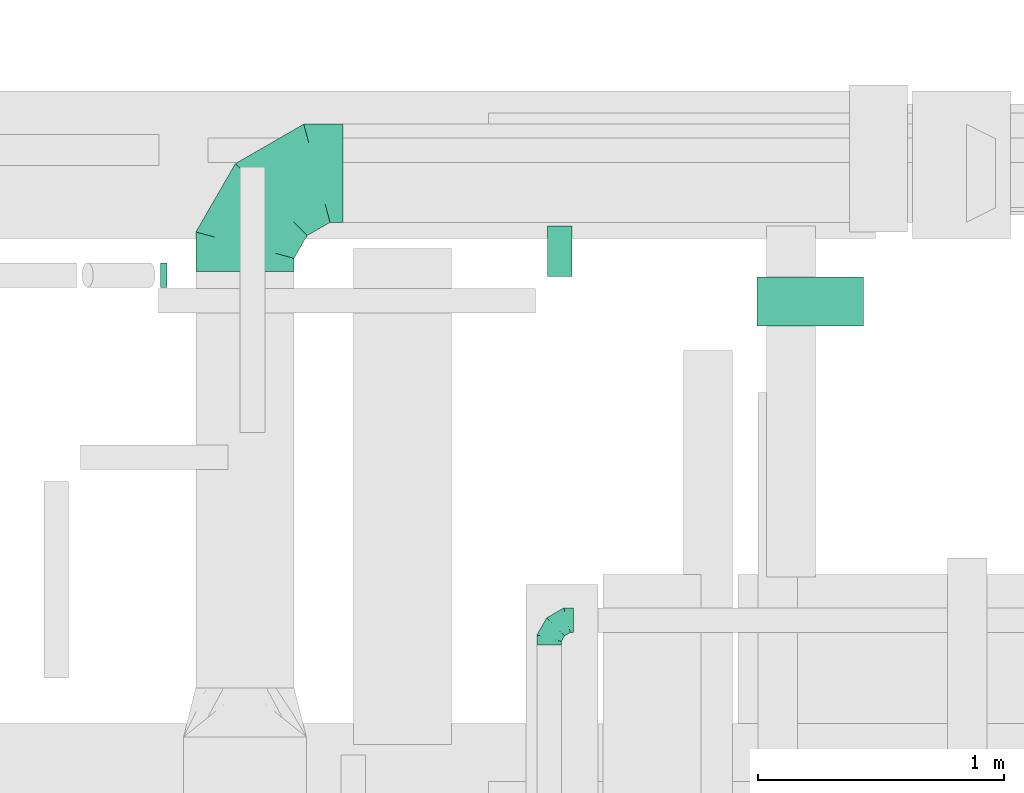
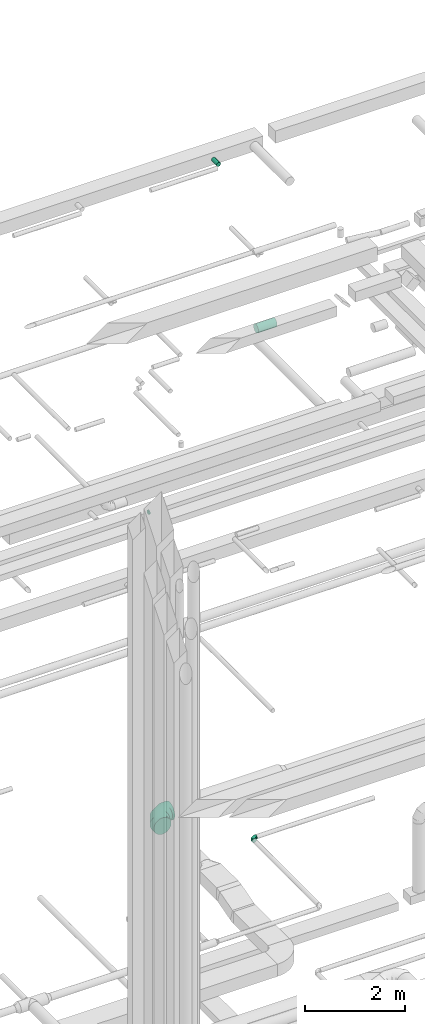
# One storey, part 158 of 337: 3 flow segments, 2 flow fittings.
"""IFC2X3 building model written with IfcOpenShell, lengths in millimetres."""

from ifc_helpers import new_model, entity, si_unit, converted_unit, derived_unit, direction, frame, origin, origin_2d_with_axis, place, context, subcontext, project, spatial, circle, extrude, faceted_brep, source, transform, mapped, material, type_object, type_shapes, element, save


model = new_model("IFC2X3")

# Units and contexts
model_context = context("Model", 3, precision=0.01, world=origin(), true_north=direction((6.12303176911189e-17, 1.0)))
body_context = subcontext(model_context, "Body", "Model", "MODEL_VIEW")
ifc_project = project(units=[si_unit("LENGTHUNIT", "METRE", prefix="MILLI"), si_unit("AREAUNIT", "SQUARE_METRE"), si_unit("VOLUMEUNIT", "CUBIC_METRE"), converted_unit("PLANEANGLEUNIT", "DEGREE", entity("IfcRatioMeasure", 0.0174532925199433), si_unit("PLANEANGLEUNIT", "RADIAN"), dimensions=[0, 0, 0, 0, 0, 0, 0]), si_unit("MASSUNIT", "GRAM", prefix="KILO"), derived_unit("MASSDENSITYUNIT", [(si_unit("MASSUNIT", "GRAM", prefix="KILO"), 1), (si_unit("LENGTHUNIT", "METRE"), -3)]), derived_unit("MOMENTOFINERTIAUNIT", [(si_unit("LENGTHUNIT", "METRE"), 4)]), si_unit("TIMEUNIT", "SECOND"), si_unit("FREQUENCYUNIT", "HERTZ"), si_unit("THERMODYNAMICTEMPERATUREUNIT", "DEGREE_CELSIUS"), derived_unit("THERMALTRANSMITTANCEUNIT", [(si_unit("MASSUNIT", "GRAM", prefix="KILO"), 1), (si_unit("THERMODYNAMICTEMPERATUREUNIT", "KELVIN"), -1), (si_unit("TIMEUNIT", "SECOND"), -3)]), derived_unit("VOLUMETRICFLOWRATEUNIT", [(si_unit("LENGTHUNIT", "METRE"), 3), (si_unit("TIMEUNIT", "SECOND"), -1)]), derived_unit("MASSFLOWRATEUNIT", [(si_unit("MASSUNIT", "GRAM", prefix="KILO"), 1), (si_unit("TIMEUNIT", "SECOND"), -1)]), derived_unit("ROTATIONALFREQUENCYUNIT", [(si_unit("TIMEUNIT", "SECOND"), -1)]), si_unit("ELECTRICCURRENTUNIT", "AMPERE"), si_unit("ELECTRICVOLTAGEUNIT", "VOLT"), si_unit("POWERUNIT", "WATT"), si_unit("FORCEUNIT", "NEWTON", prefix="KILO"), si_unit("ILLUMINANCEUNIT", "LUX"), si_unit("LUMINOUSFLUXUNIT", "LUMEN"), si_unit("LUMINOUSINTENSITYUNIT", "CANDELA"), derived_unit("USERDEFINED", [(si_unit("MASSUNIT", "GRAM", prefix="KILO"), -1), (si_unit("LENGTHUNIT", "METRE"), -2), (si_unit("TIMEUNIT", "SECOND"), 3), (si_unit("LUMINOUSFLUXUNIT", "LUMEN"), 1)]), derived_unit("LINEARVELOCITYUNIT", [(si_unit("LENGTHUNIT", "METRE"), 1), (si_unit("TIMEUNIT", "SECOND"), -1)]), si_unit("PRESSUREUNIT", "PASCAL"), derived_unit("USERDEFINED", [(si_unit("LENGTHUNIT", "METRE"), -2), (si_unit("MASSUNIT", "GRAM", prefix="KILO"), 1), (si_unit("TIMEUNIT", "SECOND"), -2)]), derived_unit("LINEARFORCEUNIT", [(si_unit("MASSUNIT", "GRAM", prefix="KILO"), 1), (si_unit("LENGTHUNIT", "METRE"), 1), (si_unit("TIMEUNIT", "SECOND"), -2), (si_unit("LENGTHUNIT", "METRE"), -1)]), derived_unit("PLANARFORCEUNIT", [(si_unit("MASSUNIT", "GRAM", prefix="KILO"), 1), (si_unit("LENGTHUNIT", "METRE"), 1), (si_unit("TIMEUNIT", "SECOND"), -2), (si_unit("LENGTHUNIT", "METRE"), -2)])], contexts=[model_context])

# Site, building, storey
site_placement = place(None, origin())
site = spatial("IfcSite", under=ifc_project, at=site_placement, CompositionType="ELEMENT")
building_placement = place(site_placement, origin())
building = spatial("IfcBuilding", under=site, at=building_placement, CompositionType="ELEMENT")
storey_placement = place(building_placement, origin())
storey = spatial("IfcBuildingStorey", under=building, at=storey_placement, CompositionType="ELEMENT", Elevation=0.0)

# Flow segments
duct_segment_type = type_object("IfcDuctSegmentType", PredefinedType="NOTDEFINED")
flow_segment_1_placement = place(storey_placement, frame((34979.29, 19353.19, 11198.4)))
element("IfcFlowSegment", 1, at=flow_segment_1_placement, inside=storey, type_object=duct_segment_type, context=body_context, shape_type="SweptSolid", body=[
    extrude(circle(Radius=50.0, at=origin_2d_with_axis()), frame((0.0, 51.6, 51.6), z_axis=(1.0, 0.0, 0.0), x_axis=(0.0, -1.0, 0.0)), (0.0, 0.0, 1.0), 26.1790715644626),
])
flow_segment_2_placement = place(storey_placement, frame((37407.95, 19195.94, 14848.4)))
element("IfcFlowSegment", 2, at=flow_segment_2_placement, inside=storey, type_object=duct_segment_type, context=body_context, shape_type="SweptSolid", body=[
    extrude(circle(Radius=100.0, at=origin_2d_with_axis()), frame((0.0, 101.6, 101.6), z_axis=(1.0, 0.0, 0.0), x_axis=(0.0, -1.0, 0.0)), (0.0, 0.0, 1.0), 433.176827525416),
])
flow_segment_3_placement = place(storey_placement, frame((36553.36, 19399.7, 19118.4)))
element("IfcFlowSegment", 3, at=flow_segment_3_placement, inside=storey, type_object=duct_segment_type, context=body_context, shape_type="SweptSolid", body=[
    extrude(circle(Radius=50.0, at=origin_2d_with_axis()), frame((51.6, 0.0, 51.6), z_axis=(0.0, 1.0, 0.0), x_axis=(-1.0, 0.0, 0.0)), (0.0, 0.0, 1.0), 205.624999999981),
])

# Flow fittings
ifc_material = material()
duct_fitting_type_1 = type_object("IfcDuctFittingType", PredefinedType="NOTDEFINED", material=ifc_material)
shared_shape_1 = source(origin(), body_context, "Body", "Brep", [
    faceted_brep([(-100.0, 0.0, -50.0), (-100.0, -12.94, -48.3), (-100.0, -25.0, -43.3), (-100.0, -35.36, -35.36), (-100.0, -43.3, -25.0), (-100.0, -48.3, -12.94), (-100.0, -50.0, 0.0), (-100.0, -48.3, 12.94), (-100.0, -43.3, 25.0), (-100.0, -35.36, 35.36), (-100.0, -25.0, 43.3), (-100.0, -12.94, 48.3), (-100.0, 0.0, 50.0), (-100.0, 12.94, 48.3), (-100.0, 25.0, 43.3), (-100.0, 35.36, 35.36), (-100.0, 43.3, 25.0), (-100.0, 48.3, 12.94), (-100.0, 50.0, 0.0), (-100.0, 48.3, -12.94), (-100.0, 43.3, -25.0), (-100.0, 35.36, -35.36), (-100.0, 25.0, -43.3), (-100.0, 12.94, -48.3), (-76.67, 12.94, 48.3), (-79.9, 25.0, 43.3), (-73.21, 0.0, 50.0), (-82.68, 35.36, 35.36), (-86.15, 48.3, 12.94), (-86.6, 50.0, 0.0), (-84.81, 43.3, 25.0), (-84.81, 43.3, -25.0), (-82.68, 35.36, -35.36), (-86.15, 48.3, -12.94), (-76.67, 12.94, -48.3), (-73.21, 0.0, -50.0), (-79.9, 25.0, -43.3), (-69.74, -12.94, -48.3), (-66.51, -25.0, -43.3), (-63.73, -35.36, -35.36), (-61.6, -43.3, -25.0), (-60.26, -48.3, -12.94), (-59.81, -50.0, 0.0), (-60.26, -48.3, 12.94), (-61.6, -43.3, 25.0), (-63.73, -35.36, 35.36), (-66.51, -25.0, 43.3), (-69.74, -12.94, 48.3), (-36.27, 36.27, 48.3), (-45.1, 45.1, 43.3), (-26.79, 26.79, 50.0), (-52.68, 52.68, 35.36), (-58.49, 58.49, 25.0), (-62.15, 62.15, 12.94), (-63.4, 63.4, 0.0), (-62.15, 62.15, -12.94), (-58.49, 58.49, -25.0), (-52.68, 52.68, -35.36), (-36.27, 36.27, -48.3), (-26.79, 26.79, -50.0), (-45.1, 45.1, -43.3), (-17.32, 17.32, -48.3), (-8.49, 8.49, -43.3), (-0.91, 0.91, -35.36), (4.9, -4.9, -25.0), (8.56, -8.56, -12.94), (9.81, -9.81, 0.0), (8.56, -8.56, 12.94), (4.9, -4.9, 25.0), (-0.91, 0.91, 35.36), (-8.49, 8.49, 43.3), (-17.32, 17.32, 48.3), (-12.94, 76.67, 48.3), (-25.0, 79.9, 43.3), (0.0, 73.21, 50.0), (-35.36, 82.68, 35.36), (-43.3, 84.81, 25.0), (-48.3, 86.15, 12.94), (-50.0, 86.6, 0.0), (-48.3, 86.15, -12.94), (-43.3, 84.81, -25.0), (-35.36, 82.68, -35.36), (-12.94, 76.67, -48.3), (0.0, 73.21, -50.0), (-25.0, 79.9, -43.3), (12.94, 69.74, -48.3), (25.0, 66.51, -43.3), (35.36, 63.73, -35.36), (43.3, 61.6, -25.0), (48.3, 60.26, -12.94), (50.0, 59.81, 0.0), (48.3, 60.26, 12.94), (43.3, 61.6, 25.0), (35.36, 63.73, 35.36), (25.0, 66.51, 43.3), (12.94, 69.74, 48.3), (-12.94, 100.0, -48.3), (-25.0, 100.0, -43.3), (-35.36, 100.0, -35.36), (-43.3, 100.0, -25.0), (-48.3, 100.0, -12.94), (-50.0, 100.0, 0.0), (-48.3, 100.0, 12.94), (-43.3, 100.0, 25.0), (-35.36, 100.0, 35.36), (-25.0, 100.0, 43.3), (-12.94, 100.0, 48.3), (0.0, 100.0, 50.0), (12.94, 100.0, 48.3), (25.0, 100.0, 43.3), (35.36, 100.0, 35.36), (43.3, 100.0, 25.0), (48.3, 100.0, 12.94), (50.0, 100.0, 0.0), (48.3, 100.0, -12.94), (43.3, 100.0, -25.0), (35.36, 100.0, -35.36), (25.0, 100.0, -43.3), (12.94, 100.0, -48.3), (0.0, 100.0, -50.0)], [[[0, 1, 2, 3, 4, 5, 6, 7, 8, 9, 10, 11, 12, 13, 14, 15, 16, 17, 18, 19, 20, 21, 22, 23]], [[24, 25, 14, 13]], [[26, 24, 13, 12]], [[14, 25, 27, 15]], [[28, 29, 18, 17]], [[30, 28, 17, 16]], [[15, 27, 30, 16]], [[20, 31, 32, 21]], [[33, 31, 20, 19]], [[18, 29, 33, 19]], [[34, 35, 0, 23]], [[36, 34, 23, 22]], [[32, 36, 22, 21]], [[2, 1, 37, 38]], [[3, 2, 38, 39]], [[0, 35, 37, 1]], [[5, 4, 40, 41]], [[6, 5, 41, 42]], [[3, 39, 40, 4]], [[6, 42, 43, 7]], [[7, 43, 44, 8]], [[8, 44, 45, 9]], [[10, 46, 47, 11]], [[11, 47, 26, 12]], [[10, 9, 45, 46]], [[48, 49, 25, 24]], [[50, 48, 24, 26]], [[27, 25, 49, 51]], [[52, 53, 28, 30]], [[51, 52, 30, 27]], [[29, 28, 53, 54]], [[55, 56, 31, 33]], [[54, 55, 33, 29]], [[57, 32, 31, 56]], [[58, 59, 35, 34]], [[60, 58, 34, 36]], [[57, 60, 36, 32]], [[37, 35, 59, 61]], [[38, 37, 61, 62]], [[39, 38, 62, 63]], [[41, 40, 64, 65]], [[42, 41, 65, 66]], [[63, 64, 40, 39]], [[43, 42, 66, 67]], [[44, 43, 67, 68]], [[68, 69, 45, 44]], [[46, 45, 69, 70]], [[47, 46, 70, 71]], [[26, 47, 71, 50]], [[72, 73, 49, 48]], [[74, 72, 48, 50]], [[51, 49, 73, 75]], [[76, 77, 53, 52]], [[75, 76, 52, 51]], [[54, 53, 77, 78]], [[79, 80, 56, 55]], [[78, 79, 55, 54]], [[81, 57, 56, 80]], [[82, 83, 59, 58]], [[84, 82, 58, 60]], [[81, 84, 60, 57]], [[61, 59, 83, 85]], [[62, 61, 85, 86]], [[63, 62, 86, 87]], [[65, 64, 88, 89]], [[66, 65, 89, 90]], [[87, 88, 64, 63]], [[67, 66, 90, 91]], [[68, 67, 91, 92]], [[92, 93, 69, 68]], [[70, 69, 93, 94]], [[71, 70, 94, 95]], [[50, 71, 95, 74]], [[96, 97, 98, 99, 100, 101, 102, 103, 104, 105, 106, 107, 108, 109, 110, 111, 112, 113, 114, 115, 116, 117, 118, 119]], [[72, 74, 107, 106]], [[73, 72, 106, 105]], [[75, 73, 105, 104]], [[77, 76, 103, 102]], [[78, 77, 102, 101]], [[75, 104, 103, 76]], [[78, 101, 100, 79]], [[79, 100, 99, 80]], [[80, 99, 98, 81]], [[96, 119, 83, 82]], [[97, 96, 82, 84]], [[84, 81, 98, 97]], [[83, 119, 118, 85]], [[85, 118, 117, 86]], [[86, 117, 116, 87]], [[88, 115, 114, 89]], [[89, 114, 113, 90]], [[87, 116, 115, 88]], [[91, 90, 113, 112]], [[92, 91, 112, 111]], [[93, 92, 111, 110]], [[95, 94, 109, 108]], [[74, 95, 108, 107]], [[110, 109, 94, 93]]]),
])
type_shapes(duct_fitting_type_1, [shared_shape_1])
flow_fitting_1_placement = place(storey_placement, frame((36561.25, 17999.47, 3600.0), z_axis=(0.0, 0.0, 1.0), x_axis=(-1.0, 0.0, 0.0)))
element("IfcFlowFitting", 4, at=flow_fitting_1_placement, inside=storey, type_object=duct_fitting_type_1, material=ifc_material, context=body_context, shape_type="MappedRepresentation", body=[
    mapped(shared_shape_1, transform((0.0, 0.0, 0.0), scale=1.0)),
])
duct_fitting_type_2 = type_object("IfcDuctFittingType", PredefinedType="NOTDEFINED", material=ifc_material)
shared_shape_2 = source(origin(), body_context, "Body", "Brep", [
    faceted_brep([(-400.0, 0.0, -200.0), (-400.0, -44.5, -194.99), (-400.0, -86.78, -180.19), (-400.0, -124.7, -156.37), (-400.0, -156.37, -124.7), (-400.0, -180.19, -86.78), (-400.0, -194.99, -44.5), (-400.0, -200.0, 0.0), (-400.0, -194.99, 44.5), (-400.0, -180.19, 86.78), (-400.0, -156.37, 124.7), (-400.0, -124.7, 156.37), (-400.0, -86.78, 180.19), (-400.0, -44.5, 194.99), (-400.0, 0.0, 200.0), (-400.0, 44.5, 194.99), (-400.0, 86.78, 180.19), (-400.0, 124.7, 156.37), (-400.0, 156.37, 124.7), (-400.0, 180.19, 86.78), (-400.0, 194.99, 44.5), (-400.0, 200.0, 0.0), (-400.0, 194.99, -44.5), (-400.0, 180.19, -86.78), (-400.0, 156.37, -124.7), (-400.0, 124.7, -156.37), (-400.0, 86.78, -180.19), (-400.0, 44.5, -194.99), (-292.82, 0.0, 200.0), (-304.75, 44.5, 194.99), (-316.07, 86.78, 180.19), (-326.23, 124.7, 156.37), (-334.72, 156.37, 124.7), (-341.1, 180.19, 86.78), (-345.07, 194.99, 44.5), (-346.41, 200.0, 0.0), (-345.07, 194.99, -44.5), (-341.1, 180.19, -86.78), (-334.72, 156.37, -124.7), (-326.23, 124.7, -156.37), (-316.07, 86.78, -180.19), (-304.75, 44.5, -194.99), (-292.82, 0.0, -200.0), (-280.9, -44.5, -194.99), (-269.57, -86.78, -180.19), (-259.41, -124.7, -156.37), (-250.92, -156.37, -124.7), (-244.54, -180.19, -86.78), (-240.57, -194.99, -44.5), (-239.23, -200.0, 0.0), (-240.57, -194.99, 44.5), (-244.54, -180.19, 86.78), (-250.92, -156.37, 124.7), (-259.41, -124.7, 156.37), (-269.57, -86.78, 180.19), (-280.9, -44.5, 194.99), (-107.18, 107.18, 200.0), (-139.76, 139.76, 194.99), (-170.7, 170.7, 180.19), (-198.46, 198.46, 156.37), (-221.65, 221.65, 124.7), (-239.09, 239.09, 86.78), (-249.92, 249.92, 44.5), (-253.59, 253.59, 0.0), (-249.92, 249.92, -44.5), (-239.09, 239.09, -86.78), (-221.65, 221.65, -124.7), (-198.46, 198.46, -156.37), (-170.7, 170.7, -180.19), (-139.76, 139.76, -194.99), (-107.18, 107.18, -200.0), (-74.6, 74.6, -194.99), (-43.65, 43.65, -180.19), (-15.89, 15.89, -156.37), (7.29, -7.29, -124.7), (24.73, -24.73, -86.78), (35.56, -35.56, -44.5), (39.23, -39.23, 0.0), (35.56, -35.56, 44.5), (24.73, -24.73, 86.78), (7.29, -7.29, 124.7), (-15.89, 15.89, 156.37), (-43.65, 43.65, 180.19), (-74.6, 74.6, 194.99), (0.0, 292.82, 200.0), (-44.5, 304.75, 194.99), (-86.78, 316.07, 180.19), (-124.7, 326.23, 156.37), (-156.37, 334.72, 124.7), (-180.19, 341.1, 86.78), (-194.99, 345.07, 44.5), (-200.0, 346.41, 0.0), (-194.99, 345.07, -44.5), (-180.19, 341.1, -86.78), (-156.37, 334.72, -124.7), (-124.7, 326.23, -156.37), (-86.78, 316.07, -180.19), (-44.5, 304.75, -194.99), (0.0, 292.82, -200.0), (44.5, 280.9, -194.99), (86.78, 269.57, -180.19), (124.7, 259.41, -156.37), (156.37, 250.92, -124.7), (180.19, 244.54, -86.78), (194.99, 240.57, -44.5), (200.0, 239.23, 0.0), (194.99, 240.57, 44.5), (180.19, 244.54, 86.78), (156.37, 250.92, 124.7), (124.7, 259.41, 156.37), (86.78, 269.57, 180.19), (44.5, 280.9, 194.99), (-44.5, 400.0, -194.99), (-86.78, 400.0, -180.19), (-124.7, 400.0, -156.37), (-156.37, 400.0, -124.7), (-180.19, 400.0, -86.78), (-194.99, 400.0, -44.5), (-200.0, 400.0, 0.0), (-194.99, 400.0, 44.5), (-180.19, 400.0, 86.78), (-156.37, 400.0, 124.7), (-124.7, 400.0, 156.37), (-86.78, 400.0, 180.19), (-44.5, 400.0, 194.99), (0.0, 400.0, 200.0), (44.5, 400.0, 194.99), (86.78, 400.0, 180.19), (124.7, 400.0, 156.37), (156.37, 400.0, 124.7), (180.19, 400.0, 86.78), (194.99, 400.0, 44.5), (200.0, 400.0, 0.0), (194.99, 400.0, -44.5), (180.19, 400.0, -86.78), (156.37, 400.0, -124.7), (124.7, 400.0, -156.37), (86.78, 400.0, -180.19), (44.5, 400.0, -194.99), (0.0, 400.0, -200.0)], [[[0, 1, 2, 3, 4, 5, 6, 7, 8, 9, 10, 11, 12, 13, 14, 15, 16, 17, 18, 19, 20, 21, 22, 23, 24, 25, 26, 27]], [[28, 29, 15, 14]], [[30, 31, 17, 16]], [[29, 30, 16, 15]], [[31, 32, 18, 17]], [[32, 33, 19, 18]], [[34, 35, 21, 20]], [[33, 34, 20, 19]], [[35, 36, 22, 21]], [[37, 38, 24, 23]], [[36, 37, 23, 22]], [[38, 39, 25, 24]], [[39, 40, 26, 25]], [[41, 42, 0, 27]], [[40, 41, 27, 26]], [[1, 0, 42, 43]], [[43, 44, 2, 1]], [[45, 3, 2, 44]], [[45, 46, 4, 3]], [[5, 4, 46, 47]], [[47, 48, 6, 5]], [[49, 7, 6, 48]], [[7, 49, 50, 8]], [[8, 50, 51, 9]], [[9, 51, 52, 10]], [[52, 53, 11, 10]], [[11, 53, 54, 12]], [[12, 54, 55, 13]], [[13, 55, 28, 14]], [[56, 57, 29, 28]], [[58, 59, 31, 30]], [[57, 58, 30, 29]], [[59, 60, 32, 31]], [[60, 61, 33, 32]], [[62, 63, 35, 34]], [[61, 62, 34, 33]], [[63, 64, 36, 35]], [[65, 66, 38, 37]], [[64, 65, 37, 36]], [[66, 67, 39, 38]], [[67, 68, 40, 39]], [[69, 70, 42, 41]], [[68, 69, 41, 40]], [[43, 42, 70, 71]], [[71, 72, 44, 43]], [[73, 45, 44, 72]], [[73, 74, 46, 45]], [[47, 46, 74, 75]], [[75, 76, 48, 47]], [[77, 49, 48, 76]], [[50, 49, 77, 78]], [[51, 50, 78, 79]], [[52, 51, 79, 80]], [[80, 81, 53, 52]], [[54, 53, 81, 82]], [[55, 54, 82, 83]], [[28, 55, 83, 56]], [[84, 85, 57, 56]], [[86, 87, 59, 58]], [[85, 86, 58, 57]], [[87, 88, 60, 59]], [[88, 89, 61, 60]], [[90, 91, 63, 62]], [[89, 90, 62, 61]], [[91, 92, 64, 63]], [[93, 94, 66, 65]], [[92, 93, 65, 64]], [[94, 95, 67, 66]], [[95, 96, 68, 67]], [[97, 98, 70, 69]], [[96, 97, 69, 68]], [[71, 70, 98, 99]], [[99, 100, 72, 71]], [[101, 73, 72, 100]], [[101, 102, 74, 73]], [[75, 74, 102, 103]], [[103, 104, 76, 75]], [[105, 77, 76, 104]], [[78, 77, 105, 106]], [[79, 78, 106, 107]], [[80, 79, 107, 108]], [[108, 109, 81, 80]], [[82, 81, 109, 110]], [[83, 82, 110, 111]], [[56, 83, 111, 84]], [[112, 113, 114, 115, 116, 117, 118, 119, 120, 121, 122, 123, 124, 125, 126, 127, 128, 129, 130, 131, 132, 133, 134, 135, 136, 137, 138, 139]], [[85, 84, 125, 124]], [[86, 85, 124, 123]], [[87, 86, 123, 122]], [[122, 121, 88, 87]], [[89, 88, 121, 120]], [[90, 89, 120, 119]], [[91, 90, 119, 118]], [[91, 118, 117, 92]], [[92, 117, 116, 93]], [[93, 116, 115, 94]], [[115, 114, 95, 94]], [[95, 114, 113, 96]], [[96, 113, 112, 97]], [[97, 112, 139, 98]], [[98, 139, 138, 99]], [[99, 138, 137, 100]], [[100, 137, 136, 101]], [[136, 135, 102, 101]], [[102, 135, 134, 103]], [[103, 134, 133, 104]], [[104, 133, 132, 105]], [[106, 105, 132, 131]], [[107, 106, 131, 130]], [[108, 107, 130, 129]], [[129, 128, 109, 108]], [[110, 109, 128, 127]], [[111, 110, 127, 126]], [[84, 111, 126, 125]]]),
])
type_shapes(duct_fitting_type_2, [shared_shape_2])
flow_fitting_2_placement = place(storey_placement, frame((35322.98, 19819.4, 3470.0), z_axis=(0.0, 0.0, 1.0), x_axis=(-1.0, 0.0, 0.0)))
element("IfcFlowFitting", 5, at=flow_fitting_2_placement, inside=storey, type_object=duct_fitting_type_2, material=ifc_material, context=body_context, shape_type="MappedRepresentation", body=[
    mapped(shared_shape_2, transform((0.0, 0.0, 0.0), scale=1.0)),
])

save(model, "model.ifc")
